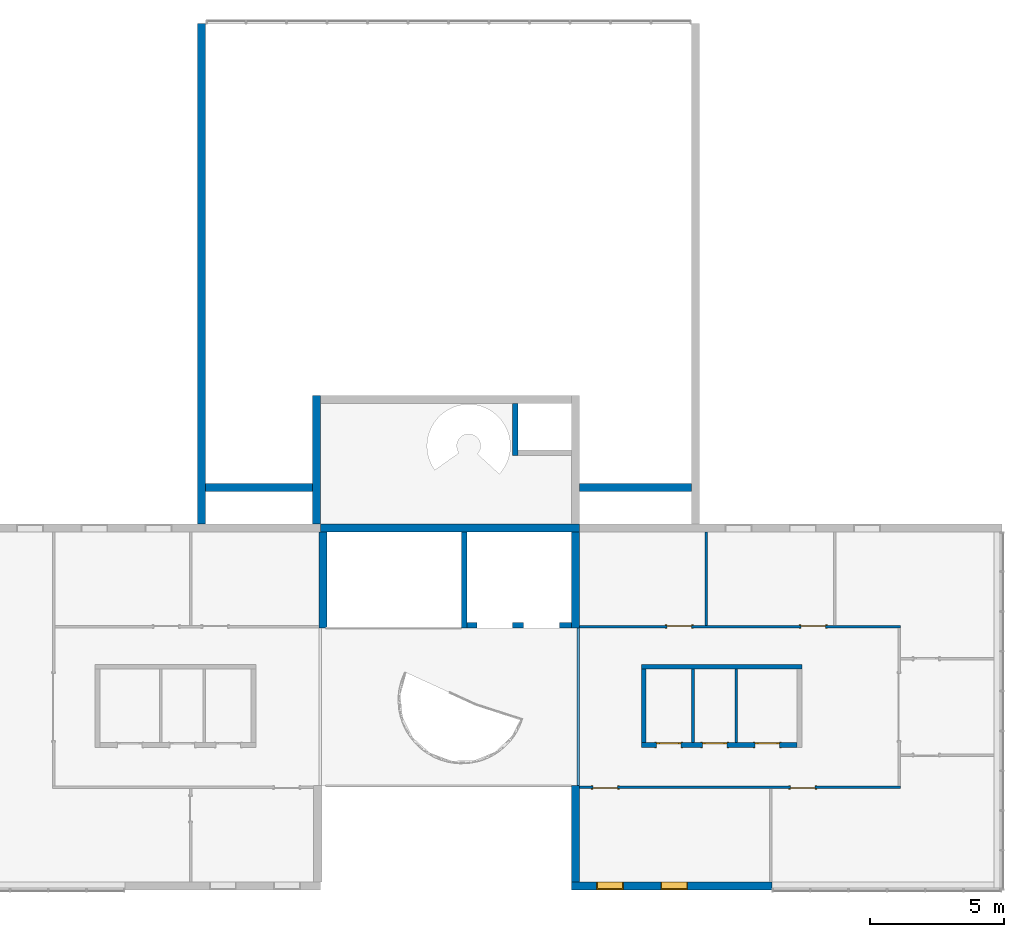
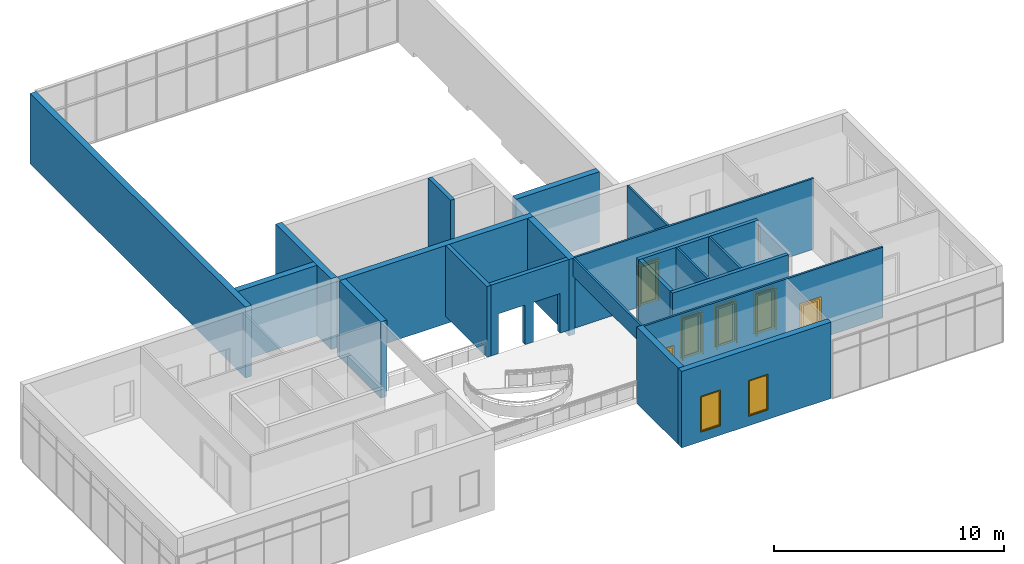
# One storey, part 11 of 13: 21 walls, 7 doors, 2 windows, 11 openings.
"""IFC2X3 building model written with IfcOpenShell, lengths in millimetres."""

from ifc_helpers import new_model, entity, si_unit, converted_unit, derived_unit, direction, frame, frame_2d, origin, place, context, subcontext, project, spatial, polyline, rectangle, outline, extrude, clip, halfspace, source, transform, mapped, material, material_list, layer, layer_set, layer_usage, type_object, type_shapes, element, fill, save


model = new_model("IFC2X3")

# Units and contexts
model_context = context("Model", 3, precision=0.01, world=origin(), true_north=direction((6.12303176911189e-17, 1.0)))
context_of_model = context(None, 3, precision=0.01, world=origin(), true_north=direction((6.12303176911189e-17, 1.0)))
body_context = subcontext(model_context, "Body", "Model", "MODEL_VIEW")
ifc_project = project(units=[si_unit("LENGTHUNIT", "METRE", prefix="MILLI"), si_unit("AREAUNIT", "SQUARE_METRE"), si_unit("VOLUMEUNIT", "CUBIC_METRE"), converted_unit("PLANEANGLEUNIT", "DEGREE", entity("IfcRatioMeasure", 0.0174532925199433), si_unit("PLANEANGLEUNIT", "RADIAN"), dimensions=[0, 0, 0, 0, 0, 0, 0]), si_unit("MASSUNIT", "GRAM", prefix="KILO"), si_unit("TIMEUNIT", "SECOND"), si_unit("FREQUENCYUNIT", "HERTZ"), si_unit("THERMODYNAMICTEMPERATUREUNIT", "DEGREE_CELSIUS"), derived_unit("THERMALTRANSMITTANCEUNIT", [(si_unit("MASSUNIT", "GRAM", prefix="KILO"), 1), (si_unit("THERMODYNAMICTEMPERATUREUNIT", "KELVIN"), -1), (si_unit("TIMEUNIT", "SECOND"), -3)]), derived_unit("VOLUMETRICFLOWRATEUNIT", [(si_unit("LENGTHUNIT", "METRE"), 3), (si_unit("TIMEUNIT", "SECOND"), -1)]), si_unit("ELECTRICCURRENTUNIT", "AMPERE"), si_unit("ELECTRICVOLTAGEUNIT", "VOLT"), si_unit("POWERUNIT", "WATT"), si_unit("FORCEUNIT", "NEWTON", prefix="KILO"), si_unit("ILLUMINANCEUNIT", "LUX"), si_unit("LUMINOUSFLUXUNIT", "LUMEN"), si_unit("LUMINOUSINTENSITYUNIT", "CANDELA"), si_unit("PRESSUREUNIT", "PASCAL")], contexts=[model_context, context_of_model])

# Site, building, storey
site_placement = place(None, origin())
site = spatial("IfcSite", under=ifc_project, at=site_placement, CompositionType="ELEMENT")
building_placement = place(site_placement, origin())
building = spatial("IfcBuilding", under=site, at=building_placement, CompositionType="ELEMENT")
storey_placement = place(building_placement, frame((0.0, 0.0, 3750.0)))
storey = spatial("IfcBuildingStorey", under=building, at=storey_placement, Name="02. 2 etg.", CompositionType="ELEMENT", Elevation=3750.00000000068)

# Walls
ifc_material_1 = material(Name="Brick, Engineering, Soldier Course")
ifc_layer_1 = layer(ifc_material_1, 300.0)
ifc_layer_set_1 = layer_set([ifc_layer_1], Name="Basic Wall:Generic - 300mm")
ifc_layer_usage_1 = layer_usage(ifc_layer_set_1, "AXIS2", "NEGATIVE", 150.0)
wall_type_1 = type_object("IfcWallType", Name="Basic Wall:Generic - 300mm", PredefinedType="STANDARD", material=ifc_layer_set_1)
wall_1_placement = place(storey_placement, frame((11209.1178561748, 240.0, 0.0), z_axis=(0.0, 0.0, 1.0), x_axis=(0.0, 1.0, 0.0)))
element("IfcWallStandardCase", 1, at=wall_1_placement, inside=storey, type_object=wall_type_1, material=ifc_layer_usage_1, Name="Basic Wall:Generic - 300mm", ObjectType="Basic Wall:Generic - 300mm:6291", context=body_context, shape_type="Clipping", body=[
    clip(extrude(rectangle(XDim=18690.0, YDim=300.000000000001, at=frame_2d((9345.0, -2.8421709430404e-14), x_axis=(-1.0, 0.0))), origin(), (0.0, 0.0, 1.0), 3749.99999999925), halfspace(frame((0.0, 0.0, -3750.0)), True)),
])
ifc_layer_usage_2 = layer_usage(ifc_layer_set_1, "AXIS2", "NEGATIVE", 150.0)
wall_2_placement = place(storey_placement, frame((15344.0, 90.0, -400.0)))
element("IfcWallStandardCase", 2, at=wall_2_placement, inside=storey, type_object=wall_type_1, material=ifc_layer_usage_2, Name="Basic Wall:Generic - 300mm", ObjectType="Basic Wall:Generic - 300mm:6291", context=body_context, shape_type="Clipping", body=[
    clip(extrude(rectangle(XDim=9669.89662713216, YDim=300.0, at=frame_2d((5134.94831356608, -1.4210854715202e-14), x_axis=(-1.0, 0.0))), origin(), (0.0, 0.0, 1.0), 4149.99999999993), halfspace(origin(), True)),
])
ifc_layer_usage_3 = layer_usage(ifc_layer_set_1, "AXIS2", "NEGATIVE", 150.0)
wall_3_placement = place(storey_placement, frame((25168.2357123495, -13140.0, -300.0), z_axis=(0.0, 0.0, 1.0), x_axis=(0.0, 1.0, 0.0)))
element("IfcWallStandardCase", 3, at=wall_3_placement, inside=storey, type_object=wall_type_1, material=ifc_layer_usage_3, Name="Basic Wall:Generic - 300mm", ObjectType="Basic Wall:Generic - 300mm:6291", context=body_context, shape_type="SweptSolid", body=[
    extrude(rectangle(XDim=3600.00000000005, YDim=300.000000000001, at=frame_2d((1800.00000000003, 1.19371179607697e-12), x_axis=(-1.0, 0.0))), origin(), (0.0, 0.0, 1.0), 4050.0),
])
ifc_layer_usage_4 = layer_usage(ifc_layer_set_1, "AXIS2", "NEGATIVE", 150.0)
wall_4_placement = place(storey_placement, frame((25168.2357123494, -3660.0, -300.0), z_axis=(0.0, 0.0, 1.0), x_axis=(0.0, 1.0, 0.0)))
element("IfcWallStandardCase", 4, at=wall_4_placement, inside=storey, type_object=wall_type_1, material=ifc_layer_usage_4, Name="Basic Wall:Generic - 300mm", ObjectType="Basic Wall:Generic - 300mm:6291", context=body_context, shape_type="SweptSolid", body=[
    extrude(rectangle(XDim=3600.00000000004, YDim=300.000000000001, at=frame_2d((1800.00000000002, -9.66338120633736e-13), x_axis=(-1.0, 0.0))), origin(), (0.0, 0.0, 1.0), 4050.0),
])
ifc_layer_usage_5 = layer_usage(ifc_layer_set_1, "AXIS2", "POSITIVE", -150.0)
wall_5_placement = place(storey_placement, frame((15740.0, -3660.0, -300.0), z_axis=(0.0, 0.0, 1.0), x_axis=(0.0, 1.0, 0.0)))
element("IfcWallStandardCase", 5, at=wall_5_placement, inside=storey, type_object=wall_type_1, material=ifc_layer_usage_5, Name="Basic Wall:Generic - 300mm", ObjectType="Basic Wall:Generic - 300mm:6291", context=body_context, shape_type="SweptSolid", body=[
    extrude(rectangle(XDim=3600.00000000001, YDim=300.000000000001, at=frame_2d((1800.00000000001, -9.9475983006414e-14), x_axis=(-1.0, 0.0))), origin(), (0.0, 0.0, 1.0), 4050.0),
])

# Wall, openings, windows
ifc_layer_usage_6 = layer_usage(ifc_layer_set_1, "AXIS2", "NEGATIVE", 150.0)
wall_6_placement = place(storey_placement, frame((32508.2357123495, -13290.0, -300.0), z_axis=(0.0, 0.0, 1.0), x_axis=(-1.0, 0.0, 0.0)))
wall_6 = element("IfcWallStandardCase", 6, at=wall_6_placement, inside=storey, type_object=wall_type_1, material=ifc_layer_usage_6, Name="Basic Wall:Generic - 300mm", ObjectType="Basic Wall:Generic - 300mm:6291", context=body_context, shape_type="SweptSolid", body=[
    extrude(rectangle(XDim=7490.0, YDim=300.000000000001, at=frame_2d((3745.0, -1.84741111297626e-13), x_axis=(-1.0, 0.0))), origin(), (0.0, 0.0, 1.0), 4050.0),
])
opening_1_placement = place(wall_6_placement, frame((3150.0, -150.0, 500.0)))
opening_1 = element("IfcOpeningElement", 7, at=opening_1_placement, cuts=wall_6, Name="M_Fixed:0406 x 0610mm:1", ObjectType="Opening", context=body_context, shape_type="SweptSolid", body=[
    extrude(rectangle(XDim=1900.0, YDim=1000.0, at=frame_2d((949.999999999998, 500.0), x_axis=(1.0, 0.0))), frame((0.0, 0.0, 0.0), z_axis=(0.0, 1.0, 0.0), x_axis=(0.0, 0.0, 1.0)), (0.0, 0.0, 1.0), 300.0),
])
opening_2_placement = place(wall_6_placement, frame((5545.0, -150.0, 500.0)))
opening_2 = element("IfcOpeningElement", 8, at=opening_2_placement, cuts=wall_6, Name="M_Fixed:0406 x 0610mm:1", ObjectType="Opening", context=body_context, shape_type="SweptSolid", body=[
    extrude(rectangle(XDim=1900.0, YDim=1000.0, at=frame_2d((949.999999999998, 500.0), x_axis=(1.0, 0.0))), frame((0.0, 0.0, 0.0), z_axis=(0.0, 1.0, 0.0), x_axis=(0.0, 0.0, 1.0)), (0.0, 0.0, 1.0), 300.0),
])
ifc_material_2 = material(Name="Glass")
ifc_material_3 = material(Name="Stainless Steel")
ifc_material_list_1 = material_list([ifc_material_2, ifc_material_3])
ifc_material_list_2 = material_list([ifc_material_2, ifc_material_3])
window_style = type_object("IfcWindowStyle", Name="0406 x 0610mm", ConstructionType="NOTDEFINED", OperationType="NOTDEFINED", ParameterTakesPrecedence=False, Sizeable=False, material=ifc_material_list_2)
shared_shape_1 = source(origin(), body_context, "Body", "SweptSolid", [
    extrude(rectangle(XDim=873.999999999997, YDim=12.0, at=frame_2d((0.0, -8.43769498715119e-15), x_axis=(1.0, 0.0))), frame((500.0, 285.0, 63.0), z_axis=(0.0, 0.0, 1.0), x_axis=(-1.0, 0.0, 0.0)), (0.0, 0.0, 1.0), 1774.00000000001),
    extrude(outline(polyline([(-481.0, -931.0), (481.0, -931.0), (481.0, 931.0), (-481.0, 931.0), (-481.0, -931.0)]), holes=[polyline([(-437.0, -887.0), (-437.0, 887.0), (437.0, 887.0), (437.0, -887.0), (-437.0, -887.0)])]), frame((500.0, 307.0, 950.0), z_axis=(0.0, -1.0, 0.0), x_axis=(-1.0, 0.0, 0.0)), (0.0, 0.0, 1.0), 44.0000000000274),
    extrude(outline(polyline([(-500.0, -950.0), (500.0, -950.0), (500.0, 950.0), (-500.0, 950.0), (-500.0, -950.0)]), holes=[polyline([(-481.0, -931.0), (-481.0, 931.0), (481.0, 931.0), (481.0, -931.0), (-481.0, -931.0)])]), frame((500.0, 326.0, 950.0), z_axis=(0.0, -1.0, 0.0), x_axis=(-1.0, 0.0, 0.0)), (0.0, 0.0, 1.0), 63.0000000000274),
    extrude(outline(polyline([(-500.0, -950.0), (500.0, -950.0), (500.0, 950.0), (-500.0, 950.0), (-500.0, -950.0)]), holes=[polyline([(-468.0, -918.0), (-468.0, 918.0), (468.0, 918.0), (468.0, -918.0), (-468.0, -918.0)])]), frame((500.0, 263.0, 950.0), z_axis=(0.0, -1.0, 0.0), x_axis=(-1.0, 0.0, 0.0)), (0.0, 0.0, 1.0), 236.999999999973),
])
type_shapes(window_style, [shared_shape_1])
window_1_placement = place(opening_1_placement, frame((0.0, -26.0, 0.0)))
window_1 = element("IfcWindow", 9, at=window_1_placement, inside=storey, type_object=window_style, material=ifc_material_list_1, Name="M_Fixed:0406 x 0610mm", ObjectType="0406 x 0610mm", OverallHeight=1900.0, OverallWidth=999.999999999998, context=body_context, shape_type="MappedRepresentation", body=[
    mapped(shared_shape_1, transform((0.0, 0.0, 0.0), scale=1.0)),
])
fill(opening_1, window_1)
ifc_material_list_3 = material_list([ifc_material_2, ifc_material_3])
window_2_placement = place(opening_2_placement, frame((0.0, -26.0, 0.0)))
window_2 = element("IfcWindow", 10, at=window_2_placement, inside=storey, type_object=window_style, material=ifc_material_list_3, Name="M_Fixed:0406 x 0610mm", ObjectType="0406 x 0610mm", OverallHeight=1900.0, OverallWidth=999.999999999998, context=body_context, shape_type="MappedRepresentation", body=[
    mapped(shared_shape_1, transform((0.0, 0.0, 0.0), scale=1.0)),
])
fill(opening_2, window_2)

# Walls
ifc_layer_usage_7 = layer_usage(ifc_layer_set_1, "AXIS2", "NEGATIVE", 150.0)
wall_7_placement = place(storey_placement, frame((15344.0, 1590.0, 0.0), z_axis=(0.0, 0.0, 1.0), x_axis=(-1.0, 0.0, 0.0)))
element("IfcWallStandardCase", 11, at=wall_7_placement, inside=storey, type_object=wall_type_1, material=ifc_layer_usage_7, Name="Basic Wall:Generic - 300mm", ObjectType="Basic Wall:Generic - 300mm:6291", context=body_context, shape_type="SweptSolid", body=[
    extrude(rectangle(XDim=3984.88214382528, YDim=300.0, at=frame_2d((1992.44107191264, 0.0), x_axis=(-1.0, 0.0))), origin(), (0.0, 0.0, 1.0), 3750.0),
])
ifc_layer_usage_8 = layer_usage(ifc_layer_set_1, "AXIS2", "NEGATIVE", 150.0)
wall_8_placement = place(storey_placement, frame((29499.1178561747, 1590.0, 0.0), z_axis=(0.0, 0.0, 1.0), x_axis=(-1.0, 0.0, 0.0)))
element("IfcWallStandardCase", 12, at=wall_8_placement, inside=storey, type_object=wall_type_1, material=ifc_layer_usage_8, Name="Basic Wall:Generic - 300mm", ObjectType="Basic Wall:Generic - 300mm:6291", context=body_context, shape_type="SweptSolid", body=[
    extrude(rectangle(XDim=4185.22122904255, YDim=300.0, at=frame_2d((2092.61061452127, 0.0), x_axis=(-1.0, 0.0))), origin(), (0.0, 0.0, 1.0), 3750.0),
])
ifc_layer_usage_9 = layer_usage(ifc_layer_set_1, "AXIS2", "NEGATIVE", 150.0)
wall_9_placement = place(storey_placement, frame((15494.0, 240.0, 0.0), z_axis=(0.0, 0.0, 1.0), x_axis=(0.0, 1.0, 0.0)))
element("IfcWallStandardCase", 13, at=wall_9_placement, inside=storey, type_object=wall_type_1, material=ifc_layer_usage_9, Name="Basic Wall:Generic - 300mm", ObjectType="Basic Wall:Generic - 300mm:6291", context=body_context, shape_type="Clipping", body=[
    clip(extrude(rectangle(XDim=4800.0, YDim=300.000000000001, at=frame_2d((2400.0, 5.6843418860808e-14), x_axis=(-1.0, 0.0))), origin(), (0.0, 0.0, 1.0), 3749.99999999993), halfspace(origin(), True)),
])

# Wall, openings, doors
ifc_material_4 = material(Name="Steel, Paint Finish, Ivory, Matte")
ifc_layer_2 = layer(ifc_material_4, 100.0)
ifc_layer_set_2 = layer_set([ifc_layer_2], Name="Basic Wall:_100mm")
ifc_layer_usage_10 = layer_usage(ifc_layer_set_2, "AXIS2", "POSITIVE", -50.0)
wall_type_2 = type_object("IfcWallType", Name="Basic Wall:_100mm", PredefinedType="STANDARD", material=ifc_layer_set_2)
wall_10_placement = place(storey_placement, frame((25318.2357123494, -3600.0, 0.0)))
wall_10 = element("IfcWallStandardCase", 14, at=wall_10_placement, inside=storey, type_object=wall_type_2, material=ifc_layer_usage_10, Name="Basic Wall:_100mm", ObjectType="Basic Wall:_100mm", context=body_context, shape_type="SweptSolid", body=[
    extrude(rectangle(XDim=11990.0, YDim=100.0, at=frame_2d((5995.00000000001, 1.27897692436818e-13), x_axis=(-1.0, 0.0))), origin(), (0.0, 0.0, 1.0), 3750.0),
])
opening_3_placement = place(wall_10_placement, frame((8275.0, -50.0, 0.0)))
opening_3 = element("IfcOpeningElement", 15, at=opening_3_placement, cuts=wall_10, Name="M_Single-Glass 1:0915 x 2134mm:1", ObjectType="Opening", context=body_context, shape_type="SweptSolid", body=[
    extrude(rectangle(XDim=914.999999999999, YDim=2134.0, at=frame_2d((1067.0, 457.5), x_axis=(0.0, 1.0))), frame((0.0, 0.0, 0.0), z_axis=(0.0, 1.0, 0.0), x_axis=(0.0, 0.0, 1.0)), (0.0, 0.0, 1.0), 100.0),
])
opening_4_placement = place(wall_10_placement, frame((3275.0, -50.0, 0.0)))
opening_4 = element("IfcOpeningElement", 16, at=opening_4_placement, cuts=wall_10, Name="M_Single-Glass 1:0915 x 2134mm:1", ObjectType="Opening", context=body_context, shape_type="SweptSolid", body=[
    extrude(rectangle(XDim=914.999999999999, YDim=2134.0, at=frame_2d((1067.0, 457.5), x_axis=(0.0, 1.0))), frame((0.0, 0.0, 0.0), z_axis=(0.0, 1.0, 0.0), x_axis=(0.0, 0.0, 1.0)), (0.0, 0.0, 1.0), 100.0),
])
ifc_material_list_4 = material_list([ifc_material_3, ifc_material_2])
ifc_material_list_5 = material_list([ifc_material_3, ifc_material_2])
door_style_1 = type_object("IfcDoorStyle", Name="0915 x 2134mm", ConstructionType="NOTDEFINED", OperationType="SINGLE_SWING_RIGHT", ParameterTakesPrecedence=False, Sizeable=False, material=ifc_material_list_5)
shared_shape_2 = source(origin(), body_context, "Body", "SweptSolid", [
    extrude(outline(polyline([(-457.500000000003, -1048.0), (-457.500000000003, 1086.0), (-533.499999999999, 1086.0), (-533.499999999999, -1124.0), (533.500000000001, -1124.0), (533.500000000001, 1086.0), (457.500000000001, 1086.0), (457.500000000001, -1048.0), (-457.500000000003, -1048.0)])), frame((457.500000000001, -25.0, 1086.0), z_axis=(0.0, -1.0, 0.0), x_axis=(-1.0, 0.0, 0.0)), (0.0, 0.0, -1.0), 25.0),
    extrude(outline(polyline([(-457.500000000001, -1048.0), (-457.500000000001, 1086.0), (-533.499999999997, 1086.0), (-533.499999999997, -1124.0), (533.499999999999, -1124.0), (533.499999999999, 1086.0), (457.499999999999, 1086.0), (457.499999999999, -1048.0), (-457.500000000001, -1048.0)])), frame((457.499999999999, 100.0, 1086.0), z_axis=(0.0, -1.0, 0.0), x_axis=(-1.0, 0.0, 0.0)), (0.0, 0.0, -1.0), 25.0000000000156),
    extrude(rectangle(XDim=6.35, YDim=711.0, at=frame_2d((-4.21884749357559e-15, 0.0), x_axis=(1.0, 0.0))), frame((457.5, 74.6000000000039, 102.0), z_axis=(0.0, 0.0, 1.0), x_axis=(0.0, 1.0, 0.0)), (0.0, 0.0, 1.0), 1930.0),
    extrude(outline(polyline([(-1067.0, -457.499999999998), (1067.0, -457.499999999998), (1067.0, 457.499999999998), (-1067.0, 457.499999999998), (-1067.0, -457.499999999998)]), holes=[polyline([(-965.0, 355.499999999998), (965.0, 355.499999999998), (965.0, -355.500000000002), (-965.0, -355.500000000002), (-965.0, 355.499999999998)])]), frame((457.499999999998, 49.0, 1067.0), z_axis=(0.0, 1.0, 0.0), x_axis=(0.0, 0.0, -1.0)), (0.0, 0.0, 1.0), 51.0),
])
type_shapes(door_style_1, [shared_shape_2])
door_1_placement = place(opening_3_placement, origin())
door_1 = element("IfcDoor", 17, at=door_1_placement, inside=storey, type_object=door_style_1, material=ifc_material_list_4, Name="M_Single-Glass 1:0915 x 2134mm", ObjectType="0915 x 2134mm", OverallHeight=2134.0, OverallWidth=915.0, context=body_context, shape_type="MappedRepresentation", body=[
    mapped(shared_shape_2, transform((0.0, 0.0, 0.0), scale=1.0)),
])
fill(opening_3, door_1)
ifc_material_list_6 = material_list([ifc_material_3, ifc_material_2])
door_2_placement = place(opening_4_placement, origin())
door_2 = element("IfcDoor", 18, at=door_2_placement, inside=storey, type_object=door_style_1, material=ifc_material_list_6, Name="M_Single-Glass 1:0915 x 2134mm", ObjectType="0915 x 2134mm", OverallHeight=2134.0, OverallWidth=915.0, context=body_context, shape_type="MappedRepresentation", body=[
    mapped(shared_shape_2, transform((0.0, 0.0, 0.0), scale=1.0)),
])
fill(opening_4, door_2)

ifc_layer_usage_11 = layer_usage(ifc_layer_set_2, "AXIS2", "POSITIVE", -50.0)
wall_11_placement = place(storey_placement, frame((25318.2357123495, -9600.0, 0.0)))
wall_11 = element("IfcWallStandardCase", 19, at=wall_11_placement, inside=storey, type_object=wall_type_2, material=ifc_layer_usage_11, Name="Basic Wall:_100mm", ObjectType="Basic Wall:_100mm", context=body_context, shape_type="SweptSolid", body=[
    extrude(rectangle(XDim=11990.0, YDim=99.9999999999989, at=frame_2d((5995.0, -1.59872115546023e-13), x_axis=(-1.0, 0.0))), origin(), (0.0, 0.0, 1.0), 3750.0),
])
opening_5_placement = place(wall_11_placement, frame((8797.5, 50.0, 0.0)))
opening_5 = element("IfcOpeningElement", 20, at=opening_5_placement, cuts=wall_11, Name="M_Single-Glass 1:0915 x 2134mm:1", ObjectType="Opening", context=body_context, shape_type="SweptSolid", body=[
    extrude(rectangle(XDim=914.999999999999, YDim=2134.0, at=frame_2d((1067.0, 457.5), x_axis=(0.0, 1.0))), frame((0.0, 0.0, 0.0), z_axis=(0.0, -1.0, 0.0), x_axis=(0.0, 0.0, 1.0)), (0.0, 0.0, 1.0), 100.0),
])
opening_6_placement = place(wall_11_placement, frame((1415.0, 50.0, 0.0)))
opening_6 = element("IfcOpeningElement", 21, at=opening_6_placement, cuts=wall_11, Name="M_Single-Glass 1:0915 x 2134mm:1", ObjectType="Opening", context=body_context, shape_type="SweptSolid", body=[
    extrude(rectangle(XDim=914.999999999999, YDim=2134.0, at=frame_2d((1067.0, 457.5), x_axis=(0.0, 1.0))), frame((0.0, 0.0, 0.0), z_axis=(0.0, -1.0, 0.0), x_axis=(0.0, 0.0, 1.0)), (0.0, 0.0, 1.0), 100.0),
])
ifc_material_list_7 = material_list([ifc_material_3, ifc_material_2])
door_3_placement = place(opening_5_placement, frame((0.0, 0.0, 0.0), z_axis=(0.0, 0.0, 1.0), x_axis=(-1.0, 0.0, 0.0)))
door_3 = element("IfcDoor", 22, at=door_3_placement, inside=storey, type_object=door_style_1, material=ifc_material_list_7, Name="M_Single-Glass 1:0915 x 2134mm", ObjectType="0915 x 2134mm", OverallHeight=2134.0, OverallWidth=915.0, context=body_context, shape_type="MappedRepresentation", body=[
    mapped(shared_shape_2, transform((0.0, 0.0, 0.0), scale=1.0)),
])
fill(opening_5, door_3)
ifc_material_list_8 = material_list([ifc_material_3, ifc_material_2])
door_4_placement = place(opening_6_placement, frame((0.0, 0.0, 0.0), z_axis=(0.0, 0.0, 1.0), x_axis=(-1.0, 0.0, 0.0)))
door_4 = element("IfcDoor", 23, at=door_4_placement, inside=storey, type_object=door_style_1, material=ifc_material_list_8, Name="M_Single-Glass 1:0915 x 2134mm", ObjectType="0915 x 2134mm", OverallHeight=2134.0, OverallWidth=915.0, context=body_context, shape_type="MappedRepresentation", body=[
    mapped(shared_shape_2, transform((0.0, 0.0, 0.0), scale=1.0)),
])
fill(opening_6, door_4)

# Walls
ifc_layer_usage_12 = layer_usage(ifc_layer_set_2, "AXIS2", "POSITIVE", -50.0)
wall_12_placement = place(storey_placement, frame((30058.2357123495, -3550.0, 0.0), z_axis=(0.0, 0.0, 1.0), x_axis=(0.0, 1.0, 0.0)))
element("IfcWallStandardCase", 24, at=wall_12_placement, inside=storey, type_object=wall_type_2, material=ifc_layer_usage_12, Name="Basic Wall:_100mm", ObjectType="Basic Wall:_100mm", context=body_context, shape_type="SweptSolid", body=[
    extrude(rectangle(XDim=3490.00000000001, YDim=100.000000000003, at=frame_2d((1745.00000000001, 0.0), x_axis=(-1.0, 0.0))), origin(), (0.0, 0.0, 1.0), 3750.0),
])
ifc_layer_usage_13 = layer_usage(ifc_layer_set_2, "AXIS2", "NEGATIVE", 50.0)
wall_13_placement = place(storey_placement, frame((31179.1178561747, -5186.65631369453, 0.0), z_axis=(0.0, 0.0, 1.0), x_axis=(0.0, -1.0, 0.0)))
element("IfcWallStandardCase", 25, at=wall_13_placement, inside=storey, type_object=wall_type_2, material=ifc_layer_usage_13, Name="Basic Wall:_100mm", ObjectType="Basic Wall:_100mm", context=body_context, shape_type="SweptSolid", body=[
    extrude(rectangle(XDim=2740.0, YDim=100.000000000003, at=frame_2d((1370.0, 0.0), x_axis=(-1.0, 0.0))), origin(), (0.0, 0.0, 1.0), 3750.0),
])
ifc_layer_usage_14 = layer_usage(ifc_layer_set_2, "AXIS2", "POSITIVE", -50.0)
wall_14_placement = place(storey_placement, frame((29557.1178561747, -5186.65631369453, 0.0), z_axis=(0.0, 0.0, 1.0), x_axis=(0.0, -1.0, 0.0)))
element("IfcWallStandardCase", 26, at=wall_14_placement, inside=storey, type_object=wall_type_2, material=ifc_layer_usage_14, Name="Basic Wall:_100mm", ObjectType="Basic Wall:_100mm", context=body_context, shape_type="SweptSolid", body=[
    extrude(rectangle(XDim=2740.0, YDim=100.000000000003, at=frame_2d((1370.0, 0.0), x_axis=(-1.0, 0.0))), origin(), (0.0, 0.0, 1.0), 3750.0),
])
ifc_layer_usage_15 = layer_usage(ifc_layer_set_2, "AXIS2", "NEGATIVE", 50.0)
wall_15_placement = place(storey_placement, frame((25268.2357123494, -3650.0, 2800.0), z_axis=(0.0, 0.0, 1.0), x_axis=(0.0, -1.0, 0.0)))
element("IfcWallStandardCase", 27, at=wall_15_placement, inside=storey, type_object=wall_type_2, material=ifc_layer_usage_15, Name="Basic Wall:_100mm", ObjectType="Basic Wall:_100mm", context=body_context, shape_type="SweptSolid", body=[
    extrude(rectangle(XDim=5890.0, YDim=100.000000000003, at=frame_2d((2945.0, -7.105427357601e-15), x_axis=(-1.0, 0.0))), origin(), (0.0, 0.0, 1.0), 950.000000000001),
])
ifc_layer_3 = layer(ifc_material_4, 180.0)
ifc_layer_set_3 = layer_set([ifc_layer_3], Name="Basic Wall:_180mm")
ifc_layer_usage_16 = layer_usage(ifc_layer_set_3, "AXIS2", "POSITIVE", -90.0)
wall_type_3 = type_object("IfcWallType", Name="Basic Wall:_180mm", PredefinedType="STANDARD", material=ifc_layer_set_3)
wall_16_placement = place(storey_placement, frame((33629.1178561747, -5096.65631369453, 0.0), z_axis=(0.0, 0.0, 1.0), x_axis=(-1.0, 0.0, 0.0)))
element("IfcWallStandardCase", 28, at=wall_16_placement, inside=storey, type_object=wall_type_3, material=ifc_layer_usage_16, Name="Basic Wall:_180mm", ObjectType="Basic Wall:_180mm", context=body_context, shape_type="SweptSolid", body=[
    extrude(rectangle(XDim=5999.99999999999, YDim=180.0, at=frame_2d((3000.0, 0.0), x_axis=(-1.0, 0.0))), origin(), (0.0, 0.0, 1.0), 3750.0),
])

# Wall, openings, doors
ifc_layer_usage_17 = layer_usage(ifc_layer_set_3, "AXIS2", "POSITIVE", -90.0)
wall_17_placement = place(storey_placement, frame((27629.1178561747, -8016.65631369453, 0.0)))
wall_17 = element("IfcWallStandardCase", 29, at=wall_17_placement, inside=storey, type_object=wall_type_3, material=ifc_layer_usage_17, Name="Basic Wall:_180mm", ObjectType="Basic Wall:_180mm", context=body_context, shape_type="SweptSolid", body=[
    extrude(rectangle(XDim=5819.99999999999, YDim=180.0, at=frame_2d((2910.0, 0.0), x_axis=(-1.0, 0.0))), origin(), (0.0, 0.0, 1.0), 3750.0),
])
opening_7_placement = place(wall_17_placement, frame((571.5, -90.0, 0.0)))
opening_7 = element("IfcOpeningElement", 30, at=opening_7_placement, cuts=wall_17, Name="M_Single-Glass 1:0915 x 2134mm:1", ObjectType="Opening", context=body_context, shape_type="SweptSolid", body=[
    extrude(rectangle(XDim=914.999999999999, YDim=2134.0, at=frame_2d((1067.0, 457.5), x_axis=(0.0, 1.0))), frame((0.0, 0.0, 0.0), z_axis=(0.0, 1.0, 0.0), x_axis=(0.0, 0.0, 1.0)), (0.0, 0.0, 1.0), 180.0),
])
opening_8_placement = place(wall_17_placement, frame((2281.5, -90.0, 0.0)))
opening_8 = element("IfcOpeningElement", 31, at=opening_8_placement, cuts=wall_17, Name="M_Single-Glass 1:0915 x 2134mm:1", ObjectType="Opening", context=body_context, shape_type="SweptSolid", body=[
    extrude(rectangle(XDim=914.999999999999, YDim=2134.0, at=frame_2d((1067.0, 457.5), x_axis=(0.0, 1.0))), frame((0.0, 0.0, 0.0), z_axis=(0.0, 1.0, 0.0), x_axis=(0.0, 0.0, 1.0)), (0.0, 0.0, 1.0), 180.0),
])
opening_9_placement = place(wall_17_placement, frame((4252.49999999999, -90.0, 0.0)))
opening_9 = element("IfcOpeningElement", 32, at=opening_9_placement, cuts=wall_17, Name="M_Single-Glass 1:0915 x 2134mm:1", ObjectType="Opening", context=body_context, shape_type="SweptSolid", body=[
    extrude(rectangle(XDim=914.999999999999, YDim=2134.0, at=frame_2d((1067.0, 457.5), x_axis=(0.0, 1.0))), frame((0.0, 0.0, 0.0), z_axis=(0.0, 1.0, 0.0), x_axis=(0.0, 0.0, 1.0)), (0.0, 0.0, 1.0), 180.0),
])
ifc_material_list_9 = material_list([ifc_material_3, ifc_material_2])
ifc_material_list_10 = material_list([ifc_material_3, ifc_material_2])
door_style_2 = type_object("IfcDoorStyle", Name="0915 x 2134mm", ConstructionType="NOTDEFINED", OperationType="SINGLE_SWING_RIGHT", ParameterTakesPrecedence=False, Sizeable=False, material=ifc_material_list_10)
shared_shape_3 = source(origin(), body_context, "Body", "SweptSolid", [
    extrude(outline(polyline([(-457.500000000003, -1048.0), (-457.500000000003, 1086.0), (-533.499999999999, 1086.0), (-533.499999999999, -1124.0), (533.500000000001, -1124.0), (533.500000000001, 1086.0), (457.500000000001, 1086.0), (457.500000000001, -1048.0), (-457.500000000003, -1048.0)])), frame((457.500000000001, -25.0, 1086.0), z_axis=(0.0, -1.0, 0.0), x_axis=(-1.0, 0.0, 0.0)), (0.0, 0.0, -1.0), 25.0),
    extrude(outline(polyline([(-457.500000000001, -1048.0), (-457.500000000001, 1086.0), (-533.499999999997, 1086.0), (-533.499999999997, -1124.0), (533.499999999999, -1124.0), (533.499999999999, 1086.0), (457.499999999999, 1086.0), (457.499999999999, -1048.0), (-457.500000000001, -1048.0)])), frame((457.499999999999, 180.0, 1086.0), z_axis=(0.0, -1.0, 0.0), x_axis=(-1.0, 0.0, 0.0)), (0.0, 0.0, -1.0), 25.0000000000156),
    extrude(rectangle(XDim=6.35, YDim=711.0, at=frame_2d((-4.21884749357559e-15, 0.0), x_axis=(1.0, 0.0))), frame((457.5, 154.600000000001, 102.0), z_axis=(0.0, 0.0, 1.0), x_axis=(0.0, 1.0, 0.0)), (0.0, 0.0, 1.0), 1930.0),
    extrude(outline(polyline([(-1067.0, -457.499999999998), (1067.0, -457.499999999998), (1067.0, 457.499999999998), (-1067.0, 457.499999999998), (-1067.0, -457.499999999998)]), holes=[polyline([(-965.0, 355.499999999998), (965.0, 355.499999999998), (965.0, -355.500000000002), (-965.0, -355.500000000002), (-965.0, 355.499999999998)])]), frame((457.499999999998, 129.0, 1067.0), z_axis=(0.0, 1.0, 0.0), x_axis=(0.0, 0.0, -1.0)), (0.0, 0.0, 1.0), 51.0),
])
type_shapes(door_style_2, [shared_shape_3])
door_5_placement = place(opening_7_placement, origin())
door_5 = element("IfcDoor", 33, at=door_5_placement, inside=storey, type_object=door_style_2, material=ifc_material_list_9, Name="M_Single-Glass 1:0915 x 2134mm", ObjectType="0915 x 2134mm", OverallHeight=2134.0, OverallWidth=915.0, context=body_context, shape_type="MappedRepresentation", body=[
    mapped(shared_shape_3, transform((0.0, 0.0, 0.0), scale=1.0)),
])
fill(opening_7, door_5)
ifc_material_list_11 = material_list([ifc_material_3, ifc_material_2])
door_6_placement = place(opening_8_placement, origin())
door_6 = element("IfcDoor", 34, at=door_6_placement, inside=storey, type_object=door_style_2, material=ifc_material_list_11, Name="M_Single-Glass 1:0915 x 2134mm", ObjectType="0915 x 2134mm", OverallHeight=2134.0, OverallWidth=915.0, context=body_context, shape_type="MappedRepresentation", body=[
    mapped(shared_shape_3, transform((0.0, 0.0, 0.0), scale=1.0)),
])
fill(opening_8, door_6)
ifc_material_list_12 = material_list([ifc_material_3, ifc_material_2])
door_7_placement = place(opening_9_placement, origin())
door_7 = element("IfcDoor", 35, at=door_7_placement, inside=storey, type_object=door_style_2, material=ifc_material_list_12, Name="M_Single-Glass 1:0915 x 2134mm", ObjectType="0915 x 2134mm", OverallHeight=2134.0, OverallWidth=915.0, context=body_context, shape_type="MappedRepresentation", body=[
    mapped(shared_shape_3, transform((0.0, 0.0, 0.0), scale=1.0)),
])
fill(opening_9, door_7)

# Walls
ifc_layer_usage_18 = layer_usage(ifc_layer_set_3, "AXIS2", "POSITIVE", -90.0)
wall_18_placement = place(storey_placement, frame((27719.1178561747, -5186.65631369453, 0.0), z_axis=(0.0, 0.0, 1.0), x_axis=(0.0, -1.0, 0.0)))
element("IfcWallStandardCase", 36, at=wall_18_placement, inside=storey, type_object=wall_type_3, material=ifc_layer_usage_18, Name="Basic Wall:_180mm", ObjectType="Basic Wall:_180mm", context=body_context, shape_type="SweptSolid", body=[
    extrude(rectangle(XDim=2740.0, YDim=180.000000000002, at=frame_2d((1370.0, 0.0), x_axis=(-1.0, 0.0))), origin(), (0.0, 0.0, 1.0), 3750.0),
])
ifc_material_5 = material(Name="Default Wall")
ifc_layer_4 = layer(ifc_material_5, 200.0)
ifc_layer_set_4 = layer_set([ifc_layer_4], Name="Basic Wall:Generic - 200mm")
ifc_layer_usage_19 = layer_usage(ifc_layer_set_4, "AXIS2", "NEGATIVE", 100.0)
wall_type_4 = type_object("IfcWallType", Name="Basic Wall:Generic - 200mm", PredefinedType="STANDARD", material=ifc_layer_set_4)
wall_19_placement = place(storey_placement, frame((21013.8966271322, -60.0, 0.0), z_axis=(0.0, 0.0, 1.0), x_axis=(0.0, -1.0, 0.0)))
element("IfcWallStandardCase", 37, at=wall_19_placement, inside=storey, type_object=wall_type_4, material=ifc_layer_usage_19, Name="Basic Wall:Generic - 200mm", ObjectType="Basic Wall:Generic - 200mm:398", context=body_context, shape_type="SweptSolid", body=[
    extrude(rectangle(XDim=3590.00000000001, YDim=199.999999999998, at=frame_2d((1795.0, 1.35003119794419e-13), x_axis=(-1.0, 0.0))), origin(), (0.0, 0.0, 1.0), 3750.0),
])

# Wall, openings
ifc_layer_usage_20 = layer_usage(ifc_layer_set_4, "AXIS2", "NEGATIVE", 100.0)
wall_20_placement = place(storey_placement, frame((21113.8966271322, -3550.0, 0.0)))
wall_20 = element("IfcWallStandardCase", 38, at=wall_20_placement, inside=storey, type_object=wall_type_4, material=ifc_layer_usage_20, Name="Basic Wall:Generic - 200mm", ObjectType="Basic Wall:Generic - 200mm:398", context=body_context, shape_type="SweptSolid", body=[
    extrude(rectangle(XDim=3904.33908521726, YDim=200.0, at=frame_2d((1952.16954260863, -3.5527136788005e-14), x_axis=(-1.0, 0.0))), origin(), (0.0, 0.0, 1.0), 3750.0),
])
opening_10_placement = place(wall_20_placement, frame((2123.33552458642, -1624.0, 0.0)))
element("IfcOpeningElement", 39, at=opening_10_placement, cuts=wall_20, Name="Basic Wall:Generic - 200mm", ObjectType="Opening", context=body_context, shape_type="SweptSolid", body=[
    extrude(rectangle(XDim=2100.0, YDim=1340.00356586779, at=frame_2d((2.27373675443232e-13, 0.0), x_axis=(1.0, 0.0))), frame((670.0017829339, 0.0, 1050.0), z_axis=(0.0, 1.0, 0.0), x_axis=(0.0, 0.0, -1.0)), (0.0, 0.0, 1.0), 3048.0),
])
opening_11_placement = place(wall_20_placement, frame((368.996439378796, -1624.0, 0.0)))
element("IfcOpeningElement", 40, at=opening_11_placement, cuts=wall_20, Name="Basic Wall:Generic - 200mm", ObjectType="Opening", context=body_context, shape_type="SweptSolid", body=[
    extrude(rectangle(XDim=2100.0, YDim=1340.00356586779, at=frame_2d((2.27373675443232e-13, 0.0), x_axis=(1.0, 0.0))), frame((670.0017829339, 0.0, 1050.0), z_axis=(0.0, 1.0, 0.0), x_axis=(0.0, 0.0, -1.0)), (0.0, 0.0, 1.0), 3048.0),
])

# Wall
ifc_layer_usage_21 = layer_usage(ifc_layer_set_4, "AXIS2", "NEGATIVE", 100.0)
wall_21_placement = place(storey_placement, frame((22913.8966271322, 4740.0, 0.0), z_axis=(0.0, 0.0, 1.0), x_axis=(0.0, -1.0, 0.0)))
element("IfcWallStandardCase", 41, at=wall_21_placement, inside=storey, type_object=wall_type_4, material=ifc_layer_usage_21, Name="Basic Wall:Generic - 200mm", ObjectType="Basic Wall:Generic - 200mm:398", context=body_context, shape_type="Clipping", body=[
    clip(extrude(rectangle(XDim=1950.0, YDim=199.999999999998, at=frame_2d((975.0, -6.82121026329696e-13), x_axis=(-1.0, 0.0))), origin(), (0.0, 0.0, 1.0), 3749.99999999993), halfspace(origin(), True)),
])

save(model, "model.ifc")
